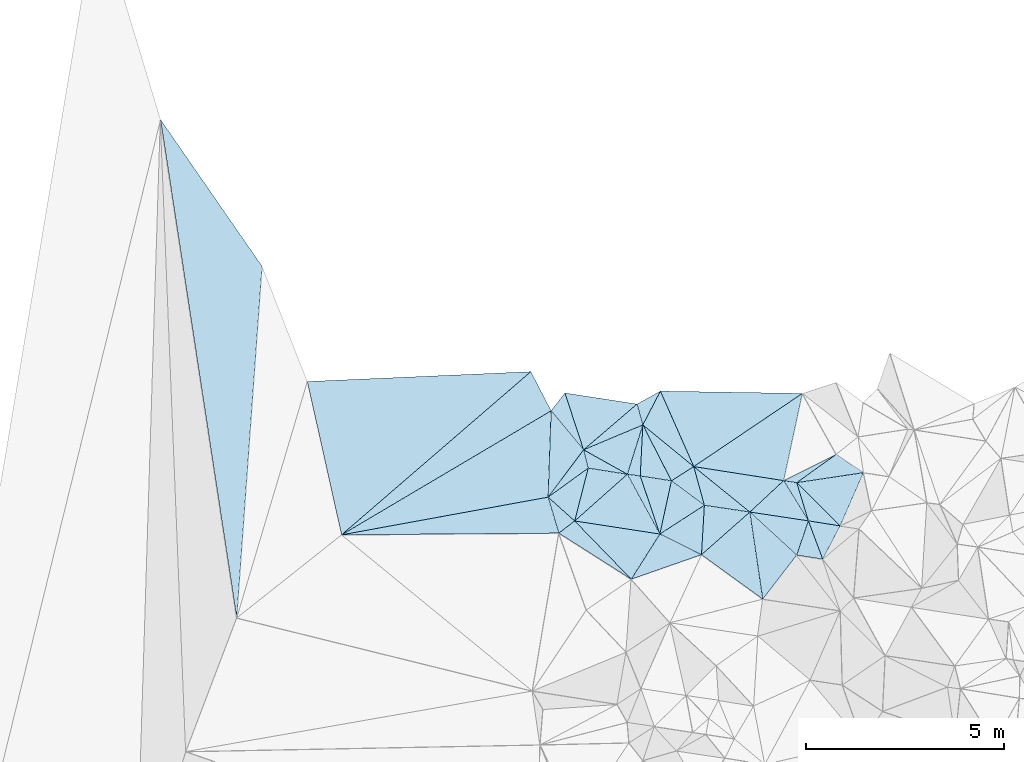
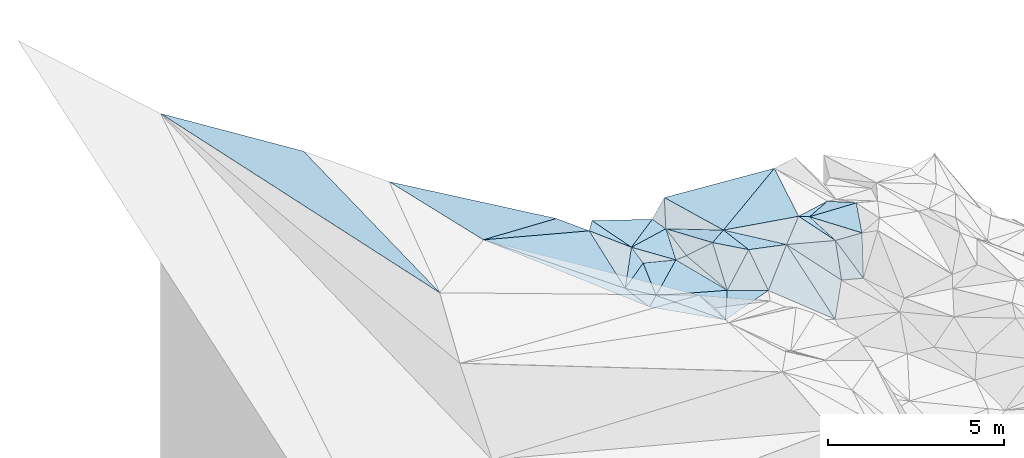
# One storey, part 141 of 275: 45 plates.
"""IFC2X3 building model written with IfcOpenShell, lengths in millimetres."""

from ifc_helpers import new_model, si_unit, frame, origin_with_axes, place, context, subcontext, project, spatial, polyline, outline, extrude, material, type_object, element, save


model = new_model("IFC2X3")

# Units and contexts
model_context = context("Model", 3, precision=1e-05, world=origin_with_axes())
body_context = subcontext(model_context, "Body", "Model", "MODEL_VIEW")
ifc_project = project(units=[si_unit("LENGTHUNIT", "METRE", prefix="MILLI"), si_unit("AREAUNIT", "SQUARE_METRE"), si_unit("VOLUMEUNIT", "CUBIC_METRE"), si_unit("MASSUNIT", "GRAM", prefix="KILO"), si_unit("TIMEUNIT", "SECOND"), si_unit("PLANEANGLEUNIT", "RADIAN"), si_unit("SOLIDANGLEUNIT", "STERADIAN"), si_unit("THERMODYNAMICTEMPERATUREUNIT", "DEGREE_CELSIUS"), si_unit("LUMINOUSINTENSITYUNIT", "LUMEN")], contexts=[model_context])

# Site, building, storey
site_placement = place(None, origin_with_axes())
site = spatial("IfcSite", under=ifc_project, at=site_placement, CompositionType="ELEMENT")
building_placement = place(site_placement, origin_with_axes())
building = spatial("IfcBuilding", under=site, at=building_placement, Name="Undefined", CompositionType="ELEMENT")
storey_placement = place(building_placement, origin_with_axes())
storey = spatial("IfcBuildingStorey", under=building, at=storey_placement, Name="Undefined", CompositionType="ELEMENT", Elevation=0.0)

# Plates
ifc_material = material()
plate_type_1 = type_object("IfcPlateType", PredefinedType="NOTDEFINED")
plate_1_placement = place(storey_placement, frame((-113649.709976674, 132523.068063055, 54019.5065304508), z_axis=(-0.0357300074015405, 0.157384410748433, -0.986890831766338), x_axis=(-0.738190561360837, 0.661507824732519, 0.132219865887932)))
element("IfcPlate", 1, at=plate_1_placement, inside=storey, type_object=plate_type_1, material=ifc_material, Name="00", context=body_context, shape_type="SweptSolid", body=[
    extrude(outline(polyline([(0.0, 0.0), (907.579223632813, 5.8826117310673e-09), (655.700378417969, 1224.31896972656), (0.0, 0.0)])), frame((-8.85201319254618e-08, 2.18876761149539e-07, -0.5000001331573), z_axis=(0.0, 0.0, 1.0), x_axis=(1.0, 0.0, 0.0)), (0.0, 0.0, 1.0), 1.0),
])
plate_type_2 = type_object("IfcPlateType", PredefinedType="NOTDEFINED")
plate_2_placement = place(storey_placement, frame((-107055.834470278, 134202.554202244, 53969.5098171844), z_axis=(-0.12923030175692, -0.149198806288677, -0.980326091313421), x_axis=(0.828817521356054, -0.558996172583966, -0.0241825418367034)))
element("IfcPlate", 2, at=plate_2_placement, inside=storey, type_object=plate_type_2, material=ifc_material, Name="00", context=body_context, shape_type="SweptSolid", body=[
    extrude(outline(polyline([(0.0, 0.0), (827.042907714844, 2.47018761001527e-09), (-432.625671386719, 1171.72314453125), (0.0, 0.0)])), frame((-8.85201319254618e-08, 2.18876761149539e-07, -0.5000001331573), z_axis=(0.0, 0.0, 1.0), x_axis=(1.0, 0.0, 0.0)), (0.0, 0.0, 1.0), 1.0),
])
plate_type_3 = type_object("IfcPlateType", PredefinedType="NOTDEFINED")
plate_3_placement = place(storey_placement, frame((-109233.627865202, 132748.09299579, 54109.582132134), z_axis=(-0.252402135820806, 0.48776701312979, -0.835689238135528), x_axis=(0.626084712380551, -0.576177125738648, -0.525393045917923)))
element("IfcPlate", 3, at=plate_3_placement, inside=storey, type_object=plate_type_3, material=ifc_material, Name="00", context=body_context, shape_type="SweptSolid", body=[
    extrude(outline(polyline([(0.0, 0.0), (1884.30358886719, 1.38043105835095e-08), (2194.12622070313, 1420.53161621094), (0.0, 0.0)])), frame((-8.85201319254618e-08, 2.18876761149539e-07, -0.5000001331573), z_axis=(0.0, 0.0, 1.0), x_axis=(1.0, 0.0, 0.0)), (0.0, 0.0, 1.0), 1.0),
])
plate_type_4 = type_object("IfcPlateType", PredefinedType="NOTDEFINED")
plate_4_placement = place(storey_placement, frame((-124090.191077229, 142640.378427777, 57860.5030731602), z_axis=(-0.0861713748906792, -0.0701333203053542, -0.993808739915481), x_axis=(0.569153392509389, -0.822185635812389, 0.00867156611180146)))
element("IfcPlate", 4, at=plate_4_placement, inside=storey, type_object=plate_type_4, material=ifc_material, Name="00", context=body_context, shape_type="SweptSolid", body=[
    extrude(outline(polyline([(0.0, 0.0), (4497.45751953125, -9.22591425478458e-09), (11427.732421875, 5605.56982421875), (0.0, 0.0)])), frame((-8.85201319254618e-08, 2.18876761149539e-07, -0.5000001331573), z_axis=(0.0, 0.0, 1.0), x_axis=(1.0, 0.0, 0.0)), (0.0, 0.0, 1.0), 1.0),
])
plate_type_5 = type_object("IfcPlateType", PredefinedType="NOTDEFINED")
plate_5_placement = place(storey_placement, frame((-110380.522085092, 132918.877806853, 54229.5556699159), z_axis=(-0.0247685821331521, 0.457986311420985, -0.888614120915324), x_axis=(0.983840692603766, -0.146502642532261, -0.10292942877529)))
element("IfcPlate", 5, at=plate_5_placement, inside=storey, type_object=plate_type_5, material=ifc_material, Name="00", context=body_context, shape_type="SweptSolid", body=[
    extrude(outline(polyline([(0.0, 0.0), (1165.84729003906, 9.03673935681582e-09), (177.038619995117, 1391.13525390625), (0.0, 0.0)])), frame((-8.85201319254618e-08, 2.18876761149539e-07, -0.5000001331573), z_axis=(0.0, 0.0, 1.0), x_axis=(1.0, 0.0, 0.0)), (0.0, 0.0, 1.0), 1.0),
])
plate_type_6 = type_object("IfcPlateType", PredefinedType="NOTDEFINED")
plate_6_placement = place(storey_placement, frame((-107757.671838222, 132525.808039957, 53869.5330686158), z_axis=(-0.100141536172348, 0.34345051983922, -0.933816584322217), x_axis=(-0.976312635007658, 0.146996487533225, 0.158762940818375)))
element("IfcPlate", 6, at=plate_6_placement, inside=storey, type_object=plate_type_6, material=ifc_material, Name="00", context=body_context, shape_type="SweptSolid", body=[
    extrude(outline(polyline([(0.0, 0.0), (1511.68774414063, -1.02154444903135e-08), (827.684143066406, 962.568969726563), (0.0, 0.0)])), frame((-8.85201319254618e-08, 2.18876761149539e-07, -0.5000001331573), z_axis=(0.0, 0.0, 1.0), x_axis=(1.0, 0.0, 0.0)), (0.0, 0.0, 1.0), 1.0),
])
plate_type_7 = type_object("IfcPlateType", PredefinedType="NOTDEFINED")
plate_7_placement = place(storey_placement, frame((-111931.889566212, 134944.308269796, 54269.5267990159), z_axis=(0.313150740021748, 0.079701729517256, -0.946353130884972), x_axis=(0.454398324534852, -0.887584013815884, 0.0756093980825375)))
element("IfcPlate", 7, at=plate_7_placement, inside=storey, type_object=plate_type_7, material=ifc_material, Name="00", context=body_context, shape_type="SweptSolid", body=[
    extrude(outline(polyline([(0.0, 0.0), (1587.10424804688, 1.48102117236704e-08), (1102.13305664063, 679.045532226563), (0.0, 0.0)])), frame((-8.85201319254618e-08, 2.18876761149539e-07, -0.5000001331573), z_axis=(0.0, 0.0, 1.0), x_axis=(1.0, 0.0, 0.0)), (0.0, 0.0, 1.0), 1.0),
])
plate_type_8 = type_object("IfcPlateType", PredefinedType="NOTDEFINED")
plate_8_placement = place(storey_placement, frame((-112322.480480567, 133700.330125641, 54079.5300975356), z_axis=(-0.25785750457634, 0.224425736371349, -0.939756668605145), x_axis=(-0.822446056021213, 0.459450741523837, 0.33539156377039)))
element("IfcPlate", 8, at=plate_8_placement, inside=storey, type_object=plate_type_8, material=ifc_material, Name="00", context=body_context, shape_type="SweptSolid", body=[
    extrude(outline(polyline([(0.0, 0.0), (1341.71533203125, 9.16770659387112e-10), (314.299163818359, 1279.57653808594), (0.0, 0.0)])), frame((-8.85201319254618e-08, 2.18876761149539e-07, -0.5000001331573), z_axis=(0.0, 0.0, 1.0), x_axis=(1.0, 0.0, 0.0)), (0.0, 0.0, 1.0), 1.0),
])
plate_type_9 = type_object("IfcPlateType", PredefinedType="NOTDEFINED")
plate_9_placement = place(storey_placement, frame((-111931.950065843, 134944.312920886, 54269.5113107101), z_axis=(0.192105599735894, 0.0889939712468012, -0.977330809721988), x_axis=(-0.0505798795567803, -0.993658361831082, -0.10042278500018)))
element("IfcPlate", 9, at=plate_9_placement, inside=storey, type_object=plate_type_9, material=ifc_material, Name="00", context=body_context, shape_type="SweptSolid", body=[
    extrude(outline(polyline([(0.0, 0.0), (1294.52697753906, 1.56578607857227e-08), (1274.98315429688, 332.442535400391), (0.0, 0.0)])), frame((-8.85201319254618e-08, 2.18876761149539e-07, -0.5000001331573), z_axis=(0.0, 0.0, 1.0), x_axis=(1.0, 0.0, 0.0)), (0.0, 0.0, 1.0), 1.0),
])
plate_type_10 = type_object("IfcPlateType", PredefinedType="NOTDEFINED")
plate_10_placement = place(storey_placement, frame((-113425.856109334, 134316.945560226, 54529.5830656665), z_axis=(-0.0321641849472331, 0.551098933884571, -0.833819782853567), x_axis=(0.822446056024578, -0.459450741515396, -0.335391563773703)))
element("IfcPlate", 10, at=plate_10_placement, inside=storey, type_object=plate_type_10, material=ifc_material, Name="00", context=body_context, shape_type="SweptSolid", body=[
    extrude(outline(polyline([(0.0, 0.0), (1341.71533203125, 9.16770659387112e-10), (412.457092285156, 391.508819580078), (0.0, 0.0)])), frame((-8.85201319254618e-08, 2.18876761149539e-07, -0.5000001331573), z_axis=(0.0, 0.0, 1.0), x_axis=(1.0, 0.0, 0.0)), (0.0, 0.0, 1.0), 1.0),
])
plate_type_11 = type_object("IfcPlateType", PredefinedType="NOTDEFINED")
plate_11_placement = place(storey_placement, frame((-112223.999529111, 131054.160711307, 53559.5183721947), z_axis=(-0.0364236001500662, 0.26627416583629, -0.963208902554527), x_axis=(-0.830381175052968, 0.528195140543064, 0.177417579806353)))
element("IfcPlate", 11, at=plate_11_placement, inside=storey, type_object=plate_type_11, material=ifc_material, Name="00", context=body_context, shape_type="SweptSolid", body=[
    extrude(outline(polyline([(0.0, 0.0), (2198.20385742188, -1.17361196316779e-08), (2041.39392089844, 484.572662353516), (0.0, 0.0)])), frame((-8.85201319254618e-08, 2.18876761149539e-07, -0.5000001331573), z_axis=(0.0, 0.0, 1.0), x_axis=(1.0, 0.0, 0.0)), (0.0, 0.0, 1.0), 1.0),
])
plate_type_12 = type_object("IfcPlateType", PredefinedType="NOTDEFINED")
plate_12_placement = place(storey_placement, frame((-107757.540532563, 132525.97895453, 53869.6450126833), z_axis=(0.162469709049793, 0.685277515821304, -0.709928390720542), x_axis=(0.984838448733953, -0.156956607490091, 0.0738772851457233)))
element("IfcPlate", 12, at=plate_12_placement, inside=storey, type_object=plate_type_12, material=ifc_material, Name="00", context=body_context, shape_type="SweptSolid", body=[
    extrude(outline(polyline([(0.0, 0.0), (812.157592773438, 3.23052518069744e-09), (444.987518310547, 1260.54992675781), (0.0, 0.0)])), frame((-8.85201319254618e-08, 2.18876761149539e-07, -0.5000001331573), z_axis=(0.0, 0.0, 1.0), x_axis=(1.0, 0.0, 0.0)), (0.0, 0.0, 1.0), 1.0),
])
plate_type_13 = type_object("IfcPlateType", PredefinedType="NOTDEFINED")
plate_13_placement = place(storey_placement, frame((-113425.946425406, 134316.709919923, 54529.5130556602), z_axis=(-0.21274303641214, 0.079856359615089, -0.97383949513622), x_axis=(-0.308066763464569, 0.940340837182698, 0.144409068880757)))
element("IfcPlate", 13, at=plate_13_placement, inside=storey, type_object=plate_type_13, material=ifc_material, Name="00", context=body_context, shape_type="SweptSolid", body=[
    extrude(outline(polyline([(0.0, 0.0), (1523.45007324219, 9.47329681366682e-09), (640.651123046875, 1667.23303222656), (0.0, 0.0)])), frame((-8.85201319254618e-08, 2.18876761149539e-07, -0.5000001331573), z_axis=(0.0, 0.0, 1.0), x_axis=(1.0, 0.0, 0.0)), (0.0, 0.0, 1.0), 1.0),
])
plate_type_14 = type_object("IfcPlateType", PredefinedType="NOTDEFINED")
plate_14_placement = place(storey_placement, frame((-109233.513020252, 132748.179110448, 54109.6245244048), z_axis=(-0.022734238512993, 0.660017814714731, -0.750905878694811), x_axis=(0.976312635153784, -0.146996487622782, -0.158762939836854)))
element("IfcPlate", 14, at=plate_14_placement, inside=storey, type_object=plate_type_14, material=ifc_material, Name="00", context=body_context, shape_type="SweptSolid", body=[
    extrude(outline(polyline([(0.0, 0.0), (1511.68774414063, -1.02154444903135e-08), (1468.55725097656, 1180.65222167969), (0.0, 0.0)])), frame((-8.85201319254618e-08, 2.18876761149539e-07, -0.5000001331573), z_axis=(0.0, 0.0, 1.0), x_axis=(1.0, 0.0, 0.0)), (0.0, 0.0, 1.0), 1.0),
])
plate_type_15 = type_object("IfcPlateType", PredefinedType="NOTDEFINED")
plate_15_placement = place(storey_placement, frame((-112322.243900216, 133700.405085987, 54079.5490029395), z_axis=(0.21531131827104, 0.374346236958641, -0.901945636443401), x_axis=(0.97541233028175, -0.126921663607988, 0.180171244213129)))
element("IfcPlate", 15, at=plate_15_placement, inside=storey, type_object=plate_type_15, material=ifc_material, Name="00", context=body_context, shape_type="SweptSolid", body=[
    extrude(outline(polyline([(0.0, 0.0), (333.016510009766, -2.69938027486205e-09), (913.167907714844, 1514.83471679688), (0.0, 0.0)])), frame((-8.85201319254618e-08, 2.18876761149539e-07, -0.5000001331573), z_axis=(0.0, 0.0, 1.0), x_axis=(1.0, 0.0, 0.0)), (0.0, 0.0, 1.0), 1.0),
])
plate_type_16 = type_object("IfcPlateType", PredefinedType="NOTDEFINED")
plate_16_placement = place(storey_placement, frame((-114319.6395821, 133123.502462974, 54139.521041382), z_axis=(0.0378517432084974, 0.284700779896553, -0.957868838339766), x_axis=(0.0335956135703614, 0.957651338472664, 0.285963719150431)))
element("IfcPlate", 16, at=plate_16_placement, inside=storey, type_object=plate_type_16, material=ifc_material, Name="00", context=body_context, shape_type="SweptSolid", body=[
    extrude(outline(polyline([(0.0, 0.0), (2273.015625, 2.85799615085125e-08), (1284.3291015625, 851.76220703125), (0.0, 0.0)])), frame((-8.85201319254618e-08, 2.18876761149539e-07, -0.5000001331573), z_axis=(0.0, 0.0, 1.0), x_axis=(1.0, 0.0, 0.0)), (0.0, 0.0, 1.0), 1.0),
])
plate_type_17 = type_object("IfcPlateType", PredefinedType="NOTDEFINED")
plate_17_placement = place(storey_placement, frame((-112077.320485819, 135470.532726844, 54329.5104052361), z_axis=(-0.194753429674492, 0.0579108896603782, -0.979141169846701), x_axis=(0.264351668550887, -0.958218062783178, -0.10925355596234)))
element("IfcPlate", 17, at=plate_17_placement, inside=storey, type_object=plate_type_17, material=ifc_material, Name="00", context=body_context, shape_type="SweptSolid", body=[
    extrude(outline(polyline([(0.0, 0.0), (549.181213378906, -1.89174897968769e-09), (727.264526367188, 1631.31433105469), (0.0, 0.0)])), frame((-8.85201319254618e-08, 2.18876761149539e-07, -0.5000001331573), z_axis=(0.0, 0.0, 1.0), x_axis=(1.0, 0.0, 0.0)), (0.0, 0.0, 1.0), 1.0),
])
plate_type_18 = type_object("IfcPlateType", PredefinedType="NOTDEFINED")
plate_18_placement = place(storey_placement, frame((-110452.929956972, 131673.18033433, 53589.5596461751), z_axis=(0.168858868872203, 0.442630558149548, -0.880661610038396), x_axis=(-0.894969627905897, 0.443185374521778, 0.051147716820722)))
element("IfcPlate", 18, at=plate_18_placement, inside=storey, type_object=plate_type_18, material=ifc_material, Name="00", context=body_context, shape_type="SweptSolid", body=[
    extrude(outline(polyline([(0.0, 0.0), (1173.07287597656, -1.64436642080545e-09), (519.916564941406, 1302.41577148438), (0.0, 0.0)])), frame((-8.85201319254618e-08, 2.18876761149539e-07, -0.5000001331573), z_axis=(0.0, 0.0, 1.0), x_axis=(1.0, 0.0, 0.0)), (0.0, 0.0, 1.0), 1.0),
])
plate_type_19 = type_object("IfcPlateType", PredefinedType="NOTDEFINED")
plate_19_placement = place(storey_placement, frame((-107396.030087856, 131559.659302515, 53019.6235035569), z_axis=(-0.0116117618318911, 0.657977186826975, -0.7529483306326), x_axis=(-0.977038661255835, 0.152742073625247, 0.148543977851896)))
element("IfcPlate", 19, at=plate_19_placement, inside=storey, type_object=plate_type_19, material=ifc_material, Name="00", context=body_context, shape_type="SweptSolid", body=[
    extrude(outline(polyline([(0.0, 0.0), (673.201293945313, 2.03726813197136e-10), (627.152648925781, 1180.5419921875), (0.0, 0.0)])), frame((-8.85201319254618e-08, 2.18876761149539e-07, -0.5000001331573), z_axis=(0.0, 0.0, 1.0), x_axis=(1.0, 0.0, 0.0)), (0.0, 0.0, 1.0), 1.0),
])
plate_type_20 = type_object("IfcPlateType", PredefinedType="NOTDEFINED")
plate_20_placement = place(storey_placement, frame((-106957.714066386, 132398.345093729, 53929.5387605487), z_axis=(0.127298690800947, 0.364570659114232, -0.922433346011179), x_axis=(-0.984838448733165, 0.156956607497431, -0.073877285140632)))
element("IfcPlate", 20, at=plate_20_placement, inside=storey, type_object=plate_type_20, material=ifc_material, Name="00", context=body_context, shape_type="SweptSolid", body=[
    extrude(outline(polyline([(0.0, 0.0), (812.157592773438, 3.23052518069744e-09), (1228.3330078125, 978.160522460938), (0.0, 0.0)])), frame((-8.85201319254618e-08, 2.18876761149539e-07, -0.5000001331573), z_axis=(0.0, 0.0, 1.0), x_axis=(1.0, 0.0, 0.0)), (0.0, 0.0, 1.0), 1.0),
])
plate_type_21 = type_object("IfcPlateType", PredefinedType="NOTDEFINED")
plate_21_placement = place(storey_placement, frame((-111502.885825854, 132192.891449002, 53649.5019357092), z_axis=(-0.0136611520543011, 0.0873698005304821, -0.996082271140197), x_axis=(0.894969627912584, -0.443185374507667, -0.0511477168259791)))
element("IfcPlate", 21, at=plate_21_placement, inside=storey, type_object=plate_type_21, material=ifc_material, Name="00", context=body_context, shape_type="SweptSolid", body=[
    extrude(outline(polyline([(0.0, 0.0), (1173.07287597656, -1.64436642080545e-09), (-136.052932739258, 1344.05712890625), (0.0, 0.0)])), frame((-8.85201319254618e-08, 2.18876761149539e-07, -0.5000001331573), z_axis=(0.0, 0.0, 1.0), x_axis=(1.0, 0.0, 0.0)), (0.0, 0.0, 1.0), 1.0),
])
plate_type_22 = type_object("IfcPlateType", PredefinedType="NOTDEFINED")
plate_22_placement = place(storey_placement, frame((-113309.022790018, 133854.544863687, 54219.5108906911), z_axis=(-0.111376075670262, 0.175432589158698, -0.978171138620113), x_axis=(0.978430967870676, -0.152959735577596, -0.138838612798043)))
element("IfcPlate", 22, at=plate_22_placement, inside=storey, type_object=plate_type_22, material=ifc_material, Name="00", context=body_context, shape_type="SweptSolid", body=[
    extrude(outline(polyline([(0.0, 0.0), (1008.36499023438, -9.02218744158745e-10), (-101.947212219238, 1385.10168457031), (0.0, 0.0)])), frame((-8.85201319254618e-08, 2.18876761149539e-07, -0.5000001331573), z_axis=(0.0, 0.0, 1.0), x_axis=(1.0, 0.0, 0.0)), (0.0, 0.0, 1.0), 1.0),
])
plate_type_23 = type_object("IfcPlateType", PredefinedType="NOTDEFINED")
plate_23_placement = place(storey_placement, frame((-108907.872469636, 130552.286783384, 52729.5754159672), z_axis=(-0.095773674419157, 0.519440111521416, -0.849122708347193), x_axis=(-0.738008598372195, 0.535375927757335, 0.410750440908688)))
element("IfcPlate", 23, at=plate_23_placement, inside=storey, type_object=plate_type_23, material=ifc_material, Name="00", context=body_context, shape_type="SweptSolid", body=[
    extrude(outline(polyline([(0.0, 0.0), (2093.72875976563, 7.01766111887991e-09), (1982.7783203125, 1703.14123535156), (0.0, 0.0)])), frame((-8.85201319254618e-08, 2.18876761149539e-07, -0.5000001331573), z_axis=(0.0, 0.0, 1.0), x_axis=(1.0, 0.0, 0.0)), (0.0, 0.0, 1.0), 1.0),
])
plate_type_24 = type_object("IfcPlateType", PredefinedType="NOTDEFINED")
plate_24_placement = place(storey_placement, frame((-111932.012414282, 134944.243245335, 54269.5017495473), z_axis=(0.0674277988346914, -0.0503637650092958, -0.996452198110073), x_axis=(0.771363478612264, -0.630816099903648, 0.0840799141622931)))
element("IfcPlate", 24, at=plate_24_placement, inside=storey, type_object=plate_type_24, material=ifc_material, Name="00", context=body_context, shape_type="SweptSolid", body=[
    extrude(outline(polyline([(0.0, 0.0), (1665.08264160156, 5.76255843043327e-09), (1455.0029296875, 633.929443359375), (0.0, 0.0)])), frame((-8.85201319254618e-08, 2.18876761149539e-07, -0.5000001331573), z_axis=(0.0, 0.0, 1.0), x_axis=(1.0, 0.0, 0.0)), (0.0, 0.0, 1.0), 1.0),
])
plate_type_25 = type_object("IfcPlateType", PredefinedType="NOTDEFINED")
plate_25_placement = place(storey_placement, frame((-114319.652940524, 133123.464072396, 54139.5109346633), z_axis=(0.011135941568238, 0.207922420792835, -0.978081927926815), x_axis=(0.73819056135925, -0.661507824734929, -0.132219865884736)))
element("IfcPlate", 25, at=plate_25_placement, inside=storey, type_object=plate_type_25, material=ifc_material, Name="00", context=body_context, shape_type="SweptSolid", body=[
    extrude(outline(polyline([(0.0, 0.0), (907.579223632813, 5.8826117310673e-09), (825.49267578125, 502.654754638672), (0.0, 0.0)])), frame((-8.85201319254618e-08, 2.18876761149539e-07, -0.5000001331573), z_axis=(0.0, 0.0, 1.0), x_axis=(1.0, 0.0, 0.0)), (0.0, 0.0, 1.0), 1.0),
])
plate_type_26 = type_object("IfcPlateType", PredefinedType="NOTDEFINED")
plate_26_placement = place(storey_placement, frame((-113425.947151371, 134316.709674978, 54529.5131948707), z_axis=(-0.214208060135323, 0.0793336362495058, -0.973561031026044), x_axis=(-0.626406995385687, 0.753604418534272, 0.199235178865324)))
element("IfcPlate", 26, at=plate_26_placement, inside=storey, type_object=plate_type_26, material=ifc_material, Name="00", context=body_context, shape_type="SweptSolid", body=[
    extrude(outline(polyline([(0.0, 0.0), (1304.99047851563, 7.46967998566106e-09), (1417.40502929688, 558.446899414063), (0.0, 0.0)])), frame((-8.85201319254618e-08, 2.18876761149539e-07, -0.5000001331573), z_axis=(0.0, 0.0, 1.0), x_axis=(1.0, 0.0, 0.0)), (0.0, 0.0, 1.0), 1.0),
])
plate_type_27 = type_object("IfcPlateType", PredefinedType="NOTDEFINED")
plate_27_placement = place(storey_placement, frame((-111502.712246588, 132193.046957329, 53649.5727542127), z_axis=(0.333512706432906, 0.398366104720141, -0.854443515545586), x_axis=(-0.304935285614638, 0.903198095379669, 0.302072296130673)))
element("IfcPlate", 27, at=plate_27_placement, inside=storey, type_object=plate_type_27, material=ifc_material, Name="00", context=body_context, shape_type="SweptSolid", body=[
    extrude(outline(polyline([(0.0, 0.0), (1622.12817382813, 1.18452589958906e-08), (1347.24243164063, 787.869140625), (0.0, 0.0)])), frame((-8.85201319254618e-08, 2.18876761149539e-07, -0.5000001331573), z_axis=(0.0, 0.0, 1.0), x_axis=(1.0, 0.0, 0.0)), (0.0, 0.0, 1.0), 1.0),
])
plate_type_28 = type_object("IfcPlateType", PredefinedType="NOTDEFINED")
plate_28_placement = place(storey_placement, frame((-114243.51399686, 135300.007264313, 54789.5638868907), z_axis=(-0.437640823549291, -0.218580899358379, -0.872177103574028), x_axis=(-0.751004547615661, -0.444531917309374, 0.488245372690668)))
element("IfcPlate", 28, at=plate_28_placement, inside=storey, type_object=plate_type_28, material=ifc_material, Name="00", context=body_context, shape_type="SweptSolid", body=[
    extrude(outline(polyline([(0.0, 0.0), (7035.39697265625, -3.03552951663733e-08), (-48.6823997497559, 1111.18408203125), (0.0, 0.0)])), frame((-8.85201319254618e-08, 2.18876761149539e-07, -0.5000001331573), z_axis=(0.0, 0.0, 1.0), x_axis=(1.0, 0.0, 0.0)), (0.0, 0.0, 1.0), 1.0),
])
plate_type_29 = type_object("IfcPlateType", PredefinedType="NOTDEFINED")
plate_29_placement = place(storey_placement, frame((-113425.982159591, 134316.91172909, 54529.5859968243), z_axis=(-0.284172976834504, 0.483449114946437, -0.827962965653974), x_axis=(0.205515166657678, -0.812778131142969, -0.545119460127236)))
element("IfcPlate", 29, at=plate_29_placement, inside=storey, type_object=plate_type_29, material=ifc_material, Name="00", context=body_context, shape_type="SweptSolid", body=[
    extrude(outline(polyline([(0.0, 0.0), (568.682678222656, 4.22005541622639e-09), (998.799499511719, 1173.62658691406), (0.0, 0.0)])), frame((-8.85201319254618e-08, 2.18876761149539e-07, -0.5000001331573), z_axis=(0.0, 0.0, 1.0), x_axis=(1.0, 0.0, 0.0)), (0.0, 0.0, 1.0), 1.0),
])
plate_type_30 = type_object("IfcPlateType", PredefinedType="NOTDEFINED")
plate_30_placement = place(storey_placement, frame((-108381.206640738, 133540.30549891, 54309.532279803), z_axis=(-0.244496079245214, 0.255428642069806, -0.935402520866869), x_axis=(0.946222425893068, -0.147924520667894, -0.287717668769598)))
element("IfcPlate", 30, at=plate_30_placement, inside=storey, type_object=plate_type_30, material=ifc_material, Name="00", context=body_context, shape_type="SweptSolid", body=[
    extrude(outline(polyline([(0.0, 0.0), (347.562957763672, -2.3283064365387e-10), (866.605590820313, 927.682434082031), (0.0, 0.0)])), frame((-8.85201319254618e-08, 2.18876761149539e-07, -0.5000001331573), z_axis=(0.0, 0.0, 1.0), x_axis=(1.0, 0.0, 0.0)), (0.0, 0.0, 1.0), 1.0),
])
plate_type_31 = type_object("IfcPlateType", PredefinedType="NOTDEFINED")
plate_31_placement = place(storey_placement, frame((-110647.664194993, 133894.031882813, 54409.515690049), z_axis=(-0.00391922890285883, 0.248703797415281, -0.968571660124343), x_axis=(0.987102726123109, -0.154050558544996, -0.0435503558229062)))
element("IfcPlate", 31, at=plate_31_placement, inside=storey, type_object=plate_type_31, material=ifc_material, Name="00", context=body_context, shape_type="SweptSolid", body=[
    extrude(outline(polyline([(0.0, 0.0), (2296.1923828125, 1.75205059349537e-08), (1585.53784179688, 943.064086914063), (0.0, 0.0)])), frame((-8.85201319254618e-08, 2.18876761149539e-07, -0.5000001331573), z_axis=(0.0, 0.0, 1.0), x_axis=(1.0, 0.0, 0.0)), (0.0, 0.0, 1.0), 1.0),
])
plate_type_32 = type_object("IfcPlateType", PredefinedType="NOTDEFINED")
plate_32_placement = place(storey_placement, frame((-108381.099803485, 133540.21961507, 54309.5019680994), z_axis=(-0.0308893572867835, 0.08364725741306, -0.996016558062005), x_axis=(-0.987102726123697, 0.154050558540728, 0.0435503558246815)))
element("IfcPlate", 32, at=plate_32_placement, inside=storey, type_object=plate_type_32, material=ifc_material, Name="00", context=body_context, shape_type="SweptSolid", body=[
    extrude(outline(polyline([(0.0, 0.0), (2296.1923828125, 1.75205059349537e-08), (-119.240875244141, 2251.55102539063), (0.0, 0.0)])), frame((-8.85201319254618e-08, 2.18876761149539e-07, -0.5000001331573), z_axis=(0.0, 0.0, 1.0), x_axis=(1.0, 0.0, 0.0)), (0.0, 0.0, 1.0), 1.0),
])
plate_type_33 = type_object("IfcPlateType", PredefinedType="NOTDEFINED")
plate_33_placement = place(storey_placement, frame((-114049.635936866, 132215.099069656, 53949.6058416709), z_axis=(-0.615065202203058, -0.0181666900623901, -0.788266939818669), x_axis=(-0.788314044040471, -0.00610926343727636, 0.61524275279666)))
element("IfcPlate", 33, at=plate_33_placement, inside=storey, type_object=plate_type_33, material=ifc_material, Name="00", context=body_context, shape_type="SweptSolid", body=[
    extrude(outline(polyline([(0.0, 0.0), (6948.47705078125, -2.66882125288248e-08), (324.452392578125, 910.4013671875), (0.0, 0.0)])), frame((-8.85201319254618e-08, 2.18876761149539e-07, -0.5000001331573), z_axis=(0.0, 0.0, 1.0), x_axis=(1.0, 0.0, 0.0)), (0.0, 0.0, 1.0), 1.0),
])
plate_type_34 = type_object("IfcPlateType", PredefinedType="NOTDEFINED")
plate_34_placement = place(storey_placement, frame((-113649.763311282, 132523.073003927, 54019.5121913747), z_axis=(-0.1424140959064, 0.167275267280965, -0.975570197496441), x_axis=(0.974345626074773, -0.149836992606519, -0.167926997816293)))
element("IfcPlate", 34, at=plate_34_placement, inside=storey, type_object=plate_type_34, material=ifc_material, Name="00", context=body_context, shape_type="SweptSolid", body=[
    extrude(outline(polyline([(0.0, 0.0), (2203.33837890625, -1.39407347887754e-08), (1686.486328125, 1248.14416503906), (0.0, 0.0)])), frame((-8.85201319254618e-08, 2.18876761149539e-07, -0.5000001331573), z_axis=(0.0, 0.0, 1.0), x_axis=(1.0, 0.0, 0.0)), (0.0, 0.0, 1.0), 1.0),
])
plate_35_placement = place(storey_placement, frame((-108052.294938733, 133488.808112046, 54209.5087315886), z_axis=(-0.164861625600337, 0.0868023570741047, -0.982489692165162), x_axis=(0.977640083538926, 0.146218037400655, -0.151129588753171)))
element("IfcPlate", 35, at=plate_35_placement, inside=storey, type_object=plate_type_34, material=ifc_material, Name="00", context=body_context, shape_type="SweptSolid", body=[
    extrude(outline(polyline([(0.0, 0.0), (1720.37780761719, -6.60656951367855e-09), (952.813903808594, 1248.09680175781), (0.0, 0.0)])), frame((-8.85201319254618e-08, 2.18876761149539e-07, -0.5000001331573), z_axis=(0.0, 0.0, 1.0), x_axis=(1.0, 0.0, 0.0)), (0.0, 0.0, 1.0), 1.0),
])
plate_type_35 = type_object("IfcPlateType", PredefinedType="NOTDEFINED")
plate_36_placement = place(storey_placement, frame((-114319.971396727, 133123.481726501, 54139.6294292201), z_axis=(-0.625786507976098, 0.243251008700073, -0.741093916586473), x_axis=(-0.778794887993199, -0.142186690304475, 0.610951280820264)))
element("IfcPlate", 36, at=plate_36_placement, inside=storey, type_object=plate_type_35, material=ifc_material, Name="00", context=body_context, shape_type="SweptSolid", body=[
    extrude(outline(polyline([(0.0, 0.0), (6686.29443359375, 3.74275259673595e-08), (28.141149520874, 2272.84130859375), (0.0, 0.0)])), frame((-8.85201319254618e-08, 2.18876761149539e-07, -0.5000001331573), z_axis=(0.0, 0.0, 1.0), x_axis=(1.0, 0.0, 0.0)), (0.0, 0.0, 1.0), 1.0),
])
plate_type_36 = type_object("IfcPlateType", PredefinedType="NOTDEFINED")
plate_37_placement = place(storey_placement, frame((-111502.946984538, 132192.949138137, 53649.5151002441), z_axis=(-0.135960165941516, 0.202722360621061, -0.969751760906563), x_axis=(-0.974345626080397, 0.149836992558411, 0.167926997826584)))
element("IfcPlate", 37, at=plate_37_placement, inside=storey, type_object=plate_type_36, material=ifc_material, Name="00", context=body_context, shape_type="SweptSolid", body=[
    extrude(outline(polyline([(0.0, 0.0), (2203.33837890625, -1.39407347887754e-08), (1096.51794433594, 1387.8935546875), (0.0, 0.0)])), frame((-8.85201319254618e-08, 2.18876761149539e-07, -0.5000001331573), z_axis=(0.0, 0.0, 1.0), x_axis=(1.0, 0.0, 0.0)), (0.0, 0.0, 1.0), 1.0),
])
plate_type_37 = type_object("IfcPlateType", PredefinedType="NOTDEFINED")
plate_38_placement = place(storey_placement, frame((-109233.541226707, 132747.929074867, 54109.5080002702), z_axis=(-0.0791261539268855, 0.159929478218402, -0.98395203834411), x_axis=(-0.983840692609306, 0.14650264249137, 0.102929428780532)))
element("IfcPlate", 38, at=plate_38_placement, inside=storey, type_object=plate_type_37, material=ifc_material, Name="00", context=body_context, shape_type="SweptSolid", body=[
    extrude(outline(polyline([(0.0, 0.0), (1165.84729003906, 9.03673935681582e-09), (1590.08813476563, 935.371459960938), (0.0, 0.0)])), frame((-8.85201319254618e-08, 2.18876761149539e-07, -0.5000001331573), z_axis=(0.0, 0.0, 1.0), x_axis=(1.0, 0.0, 0.0)), (0.0, 0.0, 1.0), 1.0),
])
plate_type_38 = type_object("IfcPlateType", PredefinedType="NOTDEFINED")
plate_39_placement = place(storey_placement, frame((-110647.50219679, 133894.042716519, 54409.5459817577), z_axis=(0.320084006634282, 0.270375978589429, -0.907988468483358), x_axis=(-0.771363478623046, 0.630816099890351, -0.0840799141631398)))
element("IfcPlate", 39, at=plate_39_placement, inside=storey, type_object=plate_type_38, material=ifc_material, Name="00", context=body_context, shape_type="SweptSolid", body=[
    extrude(outline(polyline([(0.0, 0.0), (1665.08251953125, 7.26868165656924e-09), (1826.09558105469, 1031.83081054688), (0.0, 0.0)])), frame((-8.85201319254618e-08, 2.18876761149539e-07, -0.5000001331573), z_axis=(0.0, 0.0, 1.0), x_axis=(1.0, 0.0, 0.0)), (0.0, 0.0, 1.0), 1.0),
])
plate_type_39 = type_object("IfcPlateType", PredefinedType="NOTDEFINED")
plate_40_placement = place(storey_placement, frame((-108052.352650254, 133488.799383605, 54209.5212712703), z_axis=(-0.280278768804939, 0.0693453989432926, -0.957410584546977), x_axis=(-0.946222425882143, 0.147924520791413, 0.287717668742021)))
element("IfcPlate", 40, at=plate_40_placement, inside=storey, type_object=plate_type_39, material=ifc_material, Name="00", context=body_context, shape_type="SweptSolid", body=[
    extrude(outline(polyline([(0.0, 0.0), (347.562957763672, -2.3283064365387e-10), (-906.310668945313, 859.477172851563), (0.0, 0.0)])), frame((-8.85201319254618e-08, 2.18876761149539e-07, -0.5000001331573), z_axis=(0.0, 0.0, 1.0), x_axis=(1.0, 0.0, 0.0)), (0.0, 0.0, 1.0), 1.0),
])
plate_type_40 = type_object("IfcPlateType", PredefinedType="NOTDEFINED")
plate_41_placement = place(storey_placement, frame((-111210.786632948, 133535.804302401, 54389.560680146), z_axis=(0.163962875881697, 0.44854687567742, -0.878590846556364), x_axis=(0.793268132199759, -0.589373914429726, -0.152853064823996)))
element("IfcPlate", 41, at=plate_41_placement, inside=storey, type_object=plate_type_40, material=ifc_material, Name="00", context=body_context, shape_type="SweptSolid", body=[
    extrude(outline(polyline([(0.0, 0.0), (1046.7568359375, 5.63886715099216e-09), (672.840087890625, 1408.22094726563), (0.0, 0.0)])), frame((-8.85201319254618e-08, 2.18876761149539e-07, -0.5000001331573), z_axis=(0.0, 0.0, 1.0), x_axis=(1.0, 0.0, 0.0)), (0.0, 0.0, 1.0), 1.0),
])
plate_type_41 = type_object("IfcPlateType", PredefinedType="NOTDEFINED")
plate_42_placement = place(storey_placement, frame((-111931.841602657, 134944.375416014, 54269.5564489967), z_axis=(0.409075998653831, 0.21399473541859, -0.887053031412721), x_axis=(-0.26435166854919, 0.958218062783381, 0.109253555964667)))
element("IfcPlate", 42, at=plate_42_placement, inside=storey, type_object=plate_type_41, material=ifc_material, Name="00", context=body_context, shape_type="SweptSolid", body=[
    extrude(outline(polyline([(0.0, 0.0), (549.181213378906, -1.89174897968769e-09), (744.016723632813, 732.829528808594), (0.0, 0.0)])), frame((-8.85201319254618e-08, 2.18876761149539e-07, -0.5000001331573), z_axis=(0.0, 0.0, 1.0), x_axis=(1.0, 0.0, 0.0)), (0.0, 0.0, 1.0), 1.0),
])
plate_type_42 = type_object("IfcPlateType", PredefinedType="NOTDEFINED")
plate_43_placement = place(storey_placement, frame((-111488.723692598, 135796.34895264, 54679.5041365299), z_axis=(-0.0535260309567673, 0.117082632870766, -0.991678688431926), x_axis=(0.998312516962688, -0.0161209024305188, -0.0557874087984786)))
element("IfcPlate", 43, at=plate_43_placement, inside=storey, type_object=plate_type_42, material=ifc_material, Name="00", context=body_context, shape_type="SweptSolid", body=[
    extrude(outline(polyline([(0.0, 0.0), (3585.03833007813, 8.61473381519318e-09), (885.34619140625, 1901.43688964844), (0.0, 0.0)])), frame((-8.85201319254618e-08, 2.18876761149539e-07, -0.5000001331573), z_axis=(0.0, 0.0, 1.0), x_axis=(1.0, 0.0, 0.0)), (0.0, 0.0, 1.0), 1.0),
])
plate_type_43 = type_object("IfcPlateType", PredefinedType="NOTDEFINED")
plate_44_placement = place(storey_placement, frame((-110380.544057455, 132918.730242526, 54229.5078472213), z_axis=(-0.0686596940808229, 0.162853109345266, -0.984258457512714), x_axis=(-0.793268132215679, 0.589373914408141, 0.152853064824599)))
element("IfcPlate", 44, at=plate_44_placement, inside=storey, type_object=plate_type_43, material=ifc_material, Name="00", context=body_context, shape_type="SweptSolid", body=[
    extrude(outline(polyline([(0.0, 0.0), (1046.7568359375, 5.63886715099216e-09), (814.229187011719, 626.043823242188), (0.0, 0.0)])), frame((-8.85201319254618e-08, 2.18876761149539e-07, -0.5000001331573), z_axis=(0.0, 0.0, 1.0), x_axis=(1.0, 0.0, 0.0)), (0.0, 0.0, 1.0), 1.0),
])
plate_type_44 = type_object("IfcPlateType", PredefinedType="NOTDEFINED")
plate_45_placement = place(storey_placement, frame((-114756.393679463, 136286.966902158, 54799.5737964163), z_axis=(-0.509218613532379, -0.119085679080873, -0.852358495393815), x_axis=(-0.665314755749338, -0.573775157408943, 0.477638298843949)))
element("IfcPlate", 45, at=plate_45_placement, inside=storey, type_object=plate_type_44, material=ifc_material, Name="00", context=body_context, shape_type="SweptSolid", body=[
    extrude(outline(polyline([(0.0, 0.0), (7170.6982421875, -2.00234353542328e-08), (5515.88525390625, 3599.01733398438), (0.0, 0.0)])), frame((-8.85201319254618e-08, 2.18876761149539e-07, -0.5000001331573), z_axis=(0.0, 0.0, 1.0), x_axis=(1.0, 0.0, 0.0)), (0.0, 0.0, 1.0), 1.0),
])

save(model, "model.ifc")
